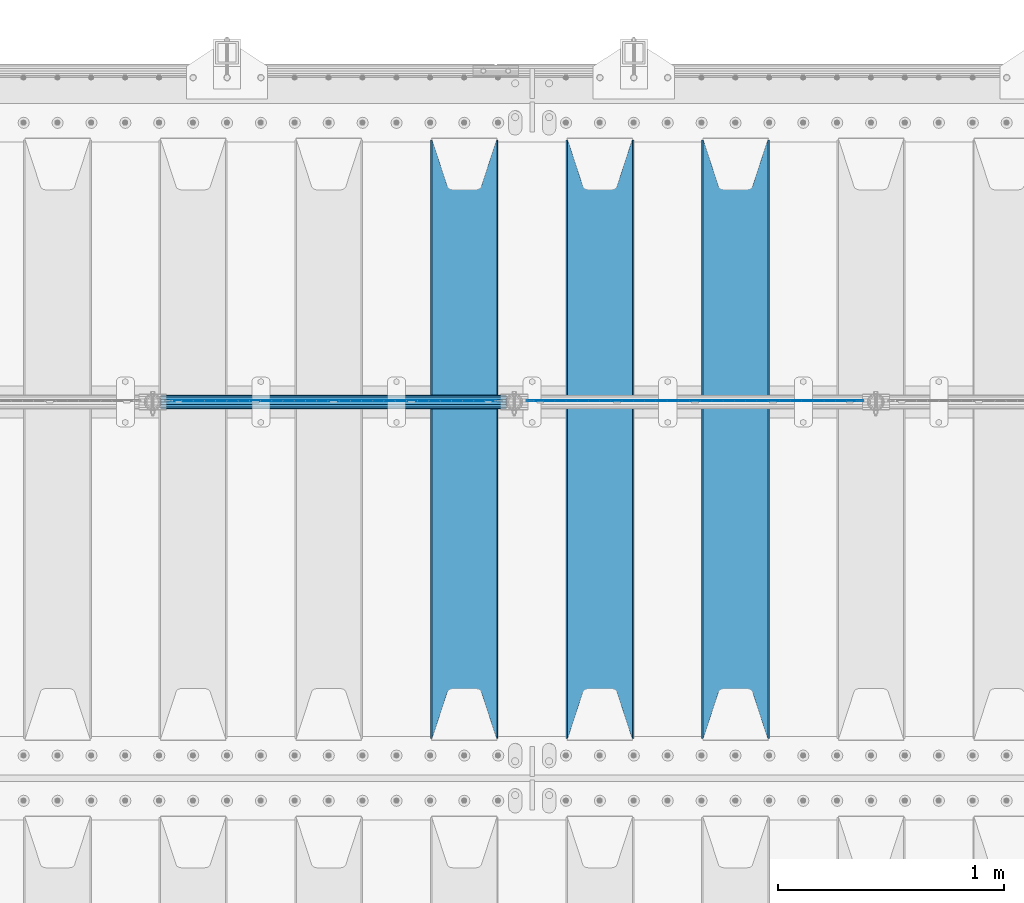
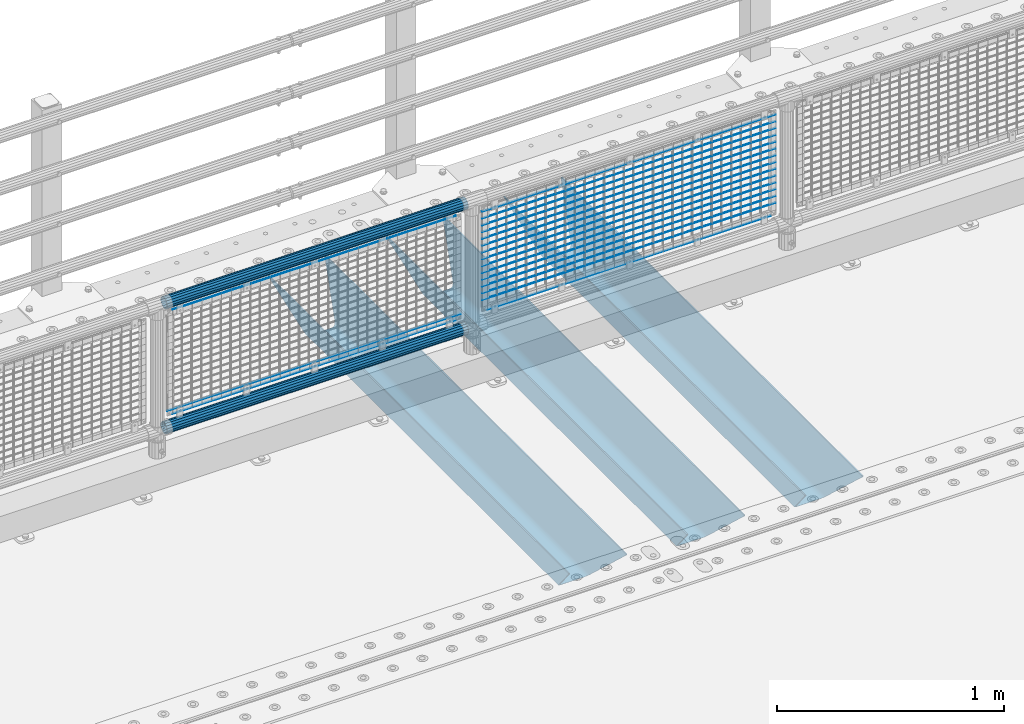
# One storey, part 96 of 208: 23 beams.
"""IFC2X3 building model written with IfcOpenShell, lengths in millimetres."""

from ifc_helpers import new_model, si_unit, frame, origin_with_axes, place, context, subcontext, project, spatial, faceted_brep, material, type_object, element, save


model = new_model("IFC2X3")

# Units and contexts
model_context = context("Model", 3, precision=1e-05, world=origin_with_axes())
body_context = subcontext(model_context, "Body", "Model", "MODEL_VIEW")
ifc_project = project(units=[si_unit("LENGTHUNIT", "METRE", prefix="MILLI"), si_unit("AREAUNIT", "SQUARE_METRE"), si_unit("VOLUMEUNIT", "CUBIC_METRE"), si_unit("MASSUNIT", "GRAM", prefix="KILO"), si_unit("TIMEUNIT", "SECOND"), si_unit("PLANEANGLEUNIT", "RADIAN"), si_unit("SOLIDANGLEUNIT", "STERADIAN"), si_unit("THERMODYNAMICTEMPERATUREUNIT", "DEGREE_CELSIUS"), si_unit("LUMINOUSINTENSITYUNIT", "LUMEN")], contexts=[model_context])

# Site, building, storey
site_placement = place(None, origin_with_axes())
site = spatial("IfcSite", under=ifc_project, at=site_placement, CompositionType="ELEMENT")
building_placement = place(site_placement, origin_with_axes())
building = spatial("IfcBuilding", under=site, at=building_placement, Name="Standard", CompositionType="ELEMENT")
storey_placement = place(building_placement, origin_with_axes())
storey = spatial("IfcBuildingStorey", under=building, at=storey_placement, Name="Undefined", CompositionType="ELEMENT", Elevation=0.0)

# Beams
ifc_material_1 = material(Name="STEEL/S355N")
beam_type_1 = type_object("IfcBeamType", PredefinedType="NOTDEFINED")
beam_1_placement = place(storey_placement, frame((-36050.0, 3175.0, -115.0), z_axis=(0.0, 0.0, 1.0), x_axis=(0.0, 1.0, 0.0)))
element("IfcBeam", 1, at=beam_1_placement, inside=storey, type_object=beam_type_1, material=ifc_material_1, context=body_context, shape_type="Brep", body=[
    faceted_brep([(0.0, 150.0, 115.0), (0.0, 143.689999999999, 115.0), (2650.00000000297, 143.689999999999, 115.0), (2650.00000000297, 150.0, 115.0), (2650.00000000297, 142.059565218402, 110.0000000031), (2650.00000000297, 148.369565218403, 110.0000000031), (2441.90079219208, -80.1103600731112, -98.0992078077845), (2437.7588105432, -77.5672621345584, -102.241189456673), (2434.06523489746, -74.4080125315522, -105.934765102404), (2430.91086095089, -70.710272125576, -109.089139048974), (2428.37322971128, -66.5649389910068, -111.626770288588), (2426.51472138055, -62.0739139532889, -113.485278619323), (2425.38102192091, -57.3475956567672, -114.618978078955), (2424.99999999987, -52.5021667386536, -115.0), (2424.99999999987, 52.5021667386536, -115.0), (2425.38102192091, 57.3475956567672, -114.618978078955), (2426.51472138055, 62.0739139532889, -113.485278619323), (2428.37322971128, 66.5649389910068, -111.626770288588), (2430.91086095089, 70.710272125576, -109.089139048974), (2434.06523489746, 74.4080125315522, -105.934765102404), (2437.7588105432, 77.5672621345584, -102.241189456673), (2441.90079219208, 80.1103600731112, -98.0992078077846), (2446.38936140511, 81.9747917625791, -93.6106385947584), (2448.24948500409, 76.2713538057251, -91.7505149957729), (2444.62967112262, 74.76777986261, -95.3703288772456), (2441.28936334126, 72.7168944282894, -98.710636658607), (2438.31067330438, 70.1691124903846, -101.689326695487), (2435.76682334747, 67.1870637758839, -104.233176652398), (2433.72034654133, 63.8440531834895, -106.279653458539), (2432.22154950041, 60.222258798236, -107.778450499454), (2431.30727574265, 56.4107117849089, -108.692724257221), (2430.99999999987, 52.5031078186876, -109.0), (2430.99999999987, -52.5031078186876, -109.0), (2431.30727574265, -56.4107117849089, -108.692724257221), (2432.22154950041, -60.222258798236, -107.778450499454), (2433.72034654133, -63.8440531834895, -106.279653458539), (2435.76682334747, -67.1870637758839, -104.233176652398), (2438.31067330438, -70.1691124903846, -101.689326695487), (2441.28936334126, -72.7168944282894, -98.7106366586071), (2444.62967112262, -74.76777986261, -95.3703288772457), (2448.24948500409, -76.2713538057251, -91.7505149957729), (2650.00000000297, -142.059565218402, 110.0000000031), (2650.00000000297, -148.369565218403, 110.0000000031), (2446.38936140511, -81.9747917625791, -93.6106385947584), (2650.00000000297, -143.689999999999, 115.0), (2650.00000000297, -150.0, 115.0), (0.0, -143.689999999999, 115.0), (0.0, -150.0, 115.0), (0.0, -148.369565218261, 110.000000002663), (203.610638597421, -81.9747917625791, -93.6106385947584), (208.099207810448, -80.1103600731112, -98.0992078077845), (212.241189459336, -77.5672621345584, -102.241189456673), (215.934765105067, -74.4080125315522, -105.934765102404), (219.089139051637, -70.710272125576, -109.089139048974), (221.626770291251, -66.5649389910068, -111.626770288588), (223.485278621986, -62.0739139532889, -113.485278619323), (224.618978081618, -57.3475956567672, -114.618978078955), (225.000000002663, -52.5021667386536, -115.0), (225.000000002663, 52.5021667386536, -115.0), (224.618978081618, 57.3475956567672, -114.618978078955), (223.485278621986, 62.0739139532889, -113.485278619323), (221.626770291251, 66.5649389910068, -111.626770288588), (219.089139051637, 70.710272125576, -109.089139048974), (215.934765105067, 74.4080125315522, -105.934765102404), (212.241189459336, 77.5672621345584, -102.241189456673), (208.099207810448, 80.1103600731112, -98.0992078077846), (203.610638597421, 81.9747917625791, -93.6106385947584), (0.0, 148.369565218261, 110.000000002663), (0.0, 142.05956521826, 110.000000002663), (201.750514998436, 76.2713538057251, -91.7505149957729), (205.370328879908, 74.76777986261, -95.3703288772456), (208.71063666127, 72.7168944282894, -98.710636658607), (211.68932669815, 70.1691124903846, -101.689326695487), (214.233176655061, 67.1870637758839, -104.233176652398), (216.279653461202, 63.8440531834895, -106.279653458539), (217.778450502116, 60.222258798236, -107.778450499454), (218.692724259884, 56.4107117849089, -108.692724257221), (219.000000002663, 52.5031078186876, -109.0), (219.000000002663, -52.5031078186876, -109.0), (218.692724259884, -56.4107117849089, -108.692724257221), (217.778450502116, -60.222258798236, -107.778450499454), (216.279653461202, -63.8440531834895, -106.279653458539), (214.233176655061, -67.1870637758839, -104.233176652398), (211.68932669815, -70.1691124903846, -101.689326695487), (208.71063666127, -72.7168944282894, -98.7106366586071), (205.370328879908, -74.76777986261, -95.3703288772457), (201.750514998436, -76.2713538057251, -91.7505149957729), (0.0, -142.05956521826, 110.000000002663)], [[[0, 1, 2, 3]], [[3, 2, 4, 5]], [[6, 7, 8, 9, 10, 11, 12, 13, 14, 15, 16, 17, 18, 19, 20, 21, 22, 5, 4, 23, 24, 25, 26, 27, 28, 29, 30, 31, 32, 33, 34, 35, 36, 37, 38, 39, 40, 41, 42, 43]], [[44, 45, 42, 41]], [[46, 47, 45, 44]], [[43, 42, 45, 47, 48, 49]], [[6, 43, 49, 50]], [[7, 6, 50, 51]], [[8, 7, 51, 52]], [[9, 8, 52, 53]], [[10, 9, 53, 54]], [[11, 10, 54, 55]], [[12, 11, 55, 56]], [[13, 12, 56, 57]], [[14, 13, 57, 58]], [[15, 14, 58, 59]], [[16, 15, 59, 60]], [[17, 16, 60, 61]], [[18, 17, 61, 62]], [[19, 18, 62, 63]], [[20, 19, 63, 64]], [[21, 20, 64, 65]], [[22, 21, 65, 66]], [[0, 3, 5, 22, 66, 67]], [[1, 0, 67, 68]], [[23, 4, 2, 1, 68, 69]], [[24, 23, 69, 70]], [[25, 24, 70, 71]], [[26, 25, 71, 72]], [[27, 26, 72, 73]], [[28, 27, 73, 74]], [[29, 28, 74, 75]], [[30, 29, 75, 76]], [[31, 30, 76, 77]], [[32, 31, 77, 78]], [[33, 32, 78, 79]], [[34, 33, 79, 80]], [[35, 34, 80, 81]], [[36, 35, 81, 82]], [[37, 36, 82, 83]], [[38, 37, 83, 84]], [[39, 38, 84, 85]], [[40, 39, 85, 86]], [[46, 44, 41, 40, 86, 87]], [[47, 46, 87, 48]], [[86, 85, 84, 83, 82, 81, 80, 79, 78, 77, 76, 75, 74, 73, 72, 71, 70, 69, 68, 67, 66, 65, 64, 63, 62, 61, 60, 59, 58, 57, 56, 55, 54, 53, 52, 51, 50, 49, 48, 87]]]),
])
beam_2_placement = place(storey_placement, frame((-36650.0, 3175.0, -115.0), z_axis=(0.0, 0.0, 1.0), x_axis=(0.0, 1.0, 0.0)))
element("IfcBeam", 2, at=beam_2_placement, inside=storey, type_object=beam_type_1, material=ifc_material_1, context=body_context, shape_type="Brep", body=[
    faceted_brep([(0.0, 150.0, 115.0), (0.0, 143.689999999999, 115.0), (2650.00000000297, 143.689999999999, 115.0), (2650.00000000297, 150.0, 115.0), (2650.00000000297, 142.059565218402, 110.0000000031), (2650.00000000297, 148.369565218403, 110.0000000031), (2441.90079219208, -80.1103600731112, -98.0992078077845), (2437.7588105432, -77.5672621345584, -102.241189456673), (2434.06523489746, -74.4080125315522, -105.934765102404), (2430.91086095089, -70.710272125576, -109.089139048974), (2428.37322971128, -66.5649389910068, -111.626770288588), (2426.51472138055, -62.0739139532889, -113.485278619323), (2425.38102192091, -57.3475956567672, -114.618978078955), (2424.99999999987, -52.5021667386536, -115.0), (2424.99999999987, 52.5021667386536, -115.0), (2425.38102192091, 57.3475956567672, -114.618978078955), (2426.51472138055, 62.0739139532889, -113.485278619323), (2428.37322971128, 66.5649389910068, -111.626770288588), (2430.91086095089, 70.710272125576, -109.089139048974), (2434.06523489746, 74.4080125315522, -105.934765102404), (2437.7588105432, 77.5672621345584, -102.241189456673), (2441.90079219208, 80.1103600731112, -98.0992078077846), (2446.38936140511, 81.9747917625791, -93.6106385947584), (2448.24948500409, 76.2713538057251, -91.7505149957729), (2444.62967112262, 74.76777986261, -95.3703288772456), (2441.28936334126, 72.7168944282894, -98.710636658607), (2438.31067330438, 70.1691124903846, -101.689326695487), (2435.76682334747, 67.1870637758839, -104.233176652398), (2433.72034654133, 63.8440531834895, -106.279653458539), (2432.22154950041, 60.222258798236, -107.778450499454), (2431.30727574265, 56.4107117849089, -108.692724257221), (2430.99999999987, 52.5031078186876, -109.0), (2430.99999999987, -52.5031078186876, -109.0), (2431.30727574265, -56.4107117849089, -108.692724257221), (2432.22154950041, -60.222258798236, -107.778450499454), (2433.72034654133, -63.8440531834895, -106.279653458539), (2435.76682334747, -67.1870637758839, -104.233176652398), (2438.31067330438, -70.1691124903846, -101.689326695487), (2441.28936334126, -72.7168944282894, -98.7106366586071), (2444.62967112262, -74.76777986261, -95.3703288772457), (2448.24948500409, -76.2713538057251, -91.7505149957729), (2650.00000000297, -142.059565218402, 110.0000000031), (2650.00000000297, -148.369565218403, 110.0000000031), (2446.38936140511, -81.9747917625791, -93.6106385947584), (2650.00000000297, -143.689999999999, 115.0), (2650.00000000297, -150.0, 115.0), (0.0, -143.689999999999, 115.0), (0.0, -150.0, 115.0), (0.0, -148.369565218261, 110.000000002663), (203.610638597421, -81.9747917625791, -93.6106385947584), (208.099207810448, -80.1103600731112, -98.0992078077845), (212.241189459336, -77.5672621345584, -102.241189456673), (215.934765105067, -74.4080125315522, -105.934765102404), (219.089139051637, -70.710272125576, -109.089139048974), (221.626770291251, -66.5649389910068, -111.626770288588), (223.485278621986, -62.0739139532889, -113.485278619323), (224.618978081618, -57.3475956567672, -114.618978078955), (225.000000002663, -52.5021667386536, -115.0), (225.000000002663, 52.5021667386536, -115.0), (224.618978081618, 57.3475956567672, -114.618978078955), (223.485278621986, 62.0739139532889, -113.485278619323), (221.626770291251, 66.5649389910068, -111.626770288588), (219.089139051637, 70.710272125576, -109.089139048974), (215.934765105067, 74.4080125315522, -105.934765102404), (212.241189459336, 77.5672621345584, -102.241189456673), (208.099207810448, 80.1103600731112, -98.0992078077846), (203.610638597421, 81.9747917625791, -93.6106385947584), (0.0, 148.369565218261, 110.000000002663), (0.0, 142.05956521826, 110.000000002663), (201.750514998436, 76.2713538057251, -91.7505149957729), (205.370328879908, 74.76777986261, -95.3703288772456), (208.71063666127, 72.7168944282894, -98.710636658607), (211.68932669815, 70.1691124903846, -101.689326695487), (214.233176655061, 67.1870637758839, -104.233176652398), (216.279653461202, 63.8440531834895, -106.279653458539), (217.778450502116, 60.222258798236, -107.778450499454), (218.692724259884, 56.4107117849089, -108.692724257221), (219.000000002663, 52.5031078186876, -109.0), (219.000000002663, -52.5031078186876, -109.0), (218.692724259884, -56.4107117849089, -108.692724257221), (217.778450502116, -60.222258798236, -107.778450499454), (216.279653461202, -63.8440531834895, -106.279653458539), (214.233176655061, -67.1870637758839, -104.233176652398), (211.68932669815, -70.1691124903846, -101.689326695487), (208.71063666127, -72.7168944282894, -98.7106366586071), (205.370328879908, -74.76777986261, -95.3703288772457), (201.750514998436, -76.2713538057251, -91.7505149957729), (0.0, -142.05956521826, 110.000000002663)], [[[0, 1, 2, 3]], [[3, 2, 4, 5]], [[6, 7, 8, 9, 10, 11, 12, 13, 14, 15, 16, 17, 18, 19, 20, 21, 22, 5, 4, 23, 24, 25, 26, 27, 28, 29, 30, 31, 32, 33, 34, 35, 36, 37, 38, 39, 40, 41, 42, 43]], [[44, 45, 42, 41]], [[46, 47, 45, 44]], [[43, 42, 45, 47, 48, 49]], [[6, 43, 49, 50]], [[7, 6, 50, 51]], [[8, 7, 51, 52]], [[9, 8, 52, 53]], [[10, 9, 53, 54]], [[11, 10, 54, 55]], [[12, 11, 55, 56]], [[13, 12, 56, 57]], [[14, 13, 57, 58]], [[15, 14, 58, 59]], [[16, 15, 59, 60]], [[17, 16, 60, 61]], [[18, 17, 61, 62]], [[19, 18, 62, 63]], [[20, 19, 63, 64]], [[21, 20, 64, 65]], [[22, 21, 65, 66]], [[0, 3, 5, 22, 66, 67]], [[1, 0, 67, 68]], [[23, 4, 2, 1, 68, 69]], [[24, 23, 69, 70]], [[25, 24, 70, 71]], [[26, 25, 71, 72]], [[27, 26, 72, 73]], [[28, 27, 73, 74]], [[29, 28, 74, 75]], [[30, 29, 75, 76]], [[31, 30, 76, 77]], [[32, 31, 77, 78]], [[33, 32, 78, 79]], [[34, 33, 79, 80]], [[35, 34, 80, 81]], [[36, 35, 81, 82]], [[37, 36, 82, 83]], [[38, 37, 83, 84]], [[39, 38, 84, 85]], [[40, 39, 85, 86]], [[46, 44, 41, 40, 86, 87]], [[47, 46, 87, 48]], [[86, 85, 84, 83, 82, 81, 80, 79, 78, 77, 76, 75, 74, 73, 72, 71, 70, 69, 68, 67, 66, 65, 64, 63, 62, 61, 60, 59, 58, 57, 56, 55, 54, 53, 52, 51, 50, 49, 48, 87]]]),
])
beam_3_placement = place(storey_placement, frame((-37250.0, 3175.0, -115.0), z_axis=(0.0, 0.0, 1.0), x_axis=(0.0, 1.0, 0.0)))
element("IfcBeam", 3, at=beam_3_placement, inside=storey, type_object=beam_type_1, material=ifc_material_1, context=body_context, shape_type="Brep", body=[
    faceted_brep([(0.0, 150.0, 115.0), (0.0, 143.689999999999, 115.0), (2650.00000000297, 143.689999999999, 115.0), (2650.00000000297, 150.0, 115.0), (2650.00000000297, 142.059565218402, 110.0000000031), (2650.00000000297, 148.369565218403, 110.0000000031), (2441.90079219208, -80.1103600731112, -98.0992078077845), (2437.7588105432, -77.5672621345584, -102.241189456673), (2434.06523489746, -74.4080125315522, -105.934765102404), (2430.91086095089, -70.710272125576, -109.089139048974), (2428.37322971128, -66.5649389910068, -111.626770288588), (2426.51472138055, -62.0739139532889, -113.485278619323), (2425.38102192091, -57.3475956567672, -114.618978078955), (2424.99999999987, -52.5021667386536, -115.0), (2424.99999999987, 52.5021667386536, -115.0), (2425.38102192091, 57.3475956567672, -114.618978078955), (2426.51472138055, 62.0739139532889, -113.485278619323), (2428.37322971128, 66.5649389910068, -111.626770288588), (2430.91086095089, 70.710272125576, -109.089139048974), (2434.06523489746, 74.4080125315522, -105.934765102404), (2437.7588105432, 77.5672621345584, -102.241189456673), (2441.90079219208, 80.1103600731112, -98.0992078077846), (2446.38936140511, 81.9747917625791, -93.6106385947584), (2448.24948500409, 76.2713538057251, -91.7505149957729), (2444.62967112262, 74.76777986261, -95.3703288772456), (2441.28936334126, 72.7168944282894, -98.710636658607), (2438.31067330438, 70.1691124903846, -101.689326695487), (2435.76682334747, 67.1870637758839, -104.233176652398), (2433.72034654133, 63.8440531834895, -106.279653458539), (2432.22154950041, 60.222258798236, -107.778450499454), (2431.30727574265, 56.4107117849089, -108.692724257221), (2430.99999999987, 52.5031078186876, -109.0), (2430.99999999987, -52.5031078186876, -109.0), (2431.30727574265, -56.4107117849089, -108.692724257221), (2432.22154950041, -60.222258798236, -107.778450499454), (2433.72034654133, -63.8440531834895, -106.279653458539), (2435.76682334747, -67.1870637758839, -104.233176652398), (2438.31067330438, -70.1691124903846, -101.689326695487), (2441.28936334126, -72.7168944282894, -98.7106366586071), (2444.62967112262, -74.76777986261, -95.3703288772457), (2448.24948500409, -76.2713538057251, -91.7505149957729), (2650.00000000297, -142.059565218402, 110.0000000031), (2650.00000000297, -148.369565218403, 110.0000000031), (2446.38936140511, -81.9747917625791, -93.6106385947584), (2650.00000000297, -143.689999999999, 115.0), (2650.00000000297, -150.0, 115.0), (0.0, -143.689999999999, 115.0), (0.0, -150.0, 115.0), (0.0, -148.369565218261, 110.000000002663), (203.610638597421, -81.9747917625791, -93.6106385947584), (208.099207810448, -80.1103600731112, -98.0992078077845), (212.241189459336, -77.5672621345584, -102.241189456673), (215.934765105067, -74.4080125315522, -105.934765102404), (219.089139051637, -70.710272125576, -109.089139048974), (221.626770291251, -66.5649389910068, -111.626770288588), (223.485278621986, -62.0739139532889, -113.485278619323), (224.618978081618, -57.3475956567672, -114.618978078955), (225.000000002663, -52.5021667386536, -115.0), (225.000000002663, 52.5021667386536, -115.0), (224.618978081618, 57.3475956567672, -114.618978078955), (223.485278621986, 62.0739139532889, -113.485278619323), (221.626770291251, 66.5649389910068, -111.626770288588), (219.089139051637, 70.710272125576, -109.089139048974), (215.934765105067, 74.4080125315522, -105.934765102404), (212.241189459336, 77.5672621345584, -102.241189456673), (208.099207810448, 80.1103600731112, -98.0992078077846), (203.610638597421, 81.9747917625791, -93.6106385947584), (0.0, 148.369565218261, 110.000000002663), (0.0, 142.05956521826, 110.000000002663), (201.750514998436, 76.2713538057251, -91.7505149957729), (205.370328879908, 74.76777986261, -95.3703288772456), (208.71063666127, 72.7168944282894, -98.710636658607), (211.68932669815, 70.1691124903846, -101.689326695487), (214.233176655061, 67.1870637758839, -104.233176652398), (216.279653461202, 63.8440531834895, -106.279653458539), (217.778450502116, 60.222258798236, -107.778450499454), (218.692724259884, 56.4107117849089, -108.692724257221), (219.000000002663, 52.5031078186876, -109.0), (219.000000002663, -52.5031078186876, -109.0), (218.692724259884, -56.4107117849089, -108.692724257221), (217.778450502116, -60.222258798236, -107.778450499454), (216.279653461202, -63.8440531834895, -106.279653458539), (214.233176655061, -67.1870637758839, -104.233176652398), (211.68932669815, -70.1691124903846, -101.689326695487), (208.71063666127, -72.7168944282894, -98.7106366586071), (205.370328879908, -74.76777986261, -95.3703288772457), (201.750514998436, -76.2713538057251, -91.7505149957729), (0.0, -142.05956521826, 110.000000002663)], [[[0, 1, 2, 3]], [[3, 2, 4, 5]], [[6, 7, 8, 9, 10, 11, 12, 13, 14, 15, 16, 17, 18, 19, 20, 21, 22, 5, 4, 23, 24, 25, 26, 27, 28, 29, 30, 31, 32, 33, 34, 35, 36, 37, 38, 39, 40, 41, 42, 43]], [[44, 45, 42, 41]], [[46, 47, 45, 44]], [[43, 42, 45, 47, 48, 49]], [[6, 43, 49, 50]], [[7, 6, 50, 51]], [[8, 7, 51, 52]], [[9, 8, 52, 53]], [[10, 9, 53, 54]], [[11, 10, 54, 55]], [[12, 11, 55, 56]], [[13, 12, 56, 57]], [[14, 13, 57, 58]], [[15, 14, 58, 59]], [[16, 15, 59, 60]], [[17, 16, 60, 61]], [[18, 17, 61, 62]], [[19, 18, 62, 63]], [[20, 19, 63, 64]], [[21, 20, 64, 65]], [[22, 21, 65, 66]], [[0, 3, 5, 22, 66, 67]], [[1, 0, 67, 68]], [[23, 4, 2, 1, 68, 69]], [[24, 23, 69, 70]], [[25, 24, 70, 71]], [[26, 25, 71, 72]], [[27, 26, 72, 73]], [[28, 27, 73, 74]], [[29, 28, 74, 75]], [[30, 29, 75, 76]], [[31, 30, 76, 77]], [[32, 31, 77, 78]], [[33, 32, 78, 79]], [[34, 33, 79, 80]], [[35, 34, 80, 81]], [[36, 35, 81, 82]], [[37, 36, 82, 83]], [[38, 37, 83, 84]], [[39, 38, 84, 85]], [[40, 39, 85, 86]], [[46, 44, 41, 40, 86, 87]], [[47, 46, 87, 48]], [[86, 85, 84, 83, 82, 81, 80, 79, 78, 77, 76, 75, 74, 73, 72, 71, 70, 69, 68, 67, 66, 65, 64, 63, 62, 61, 60, 59, 58, 57, 56, 55, 54, 53, 52, 51, 50, 49, 48, 87]]]),
])
ifc_material_2 = material(Name="Misc_Undefined")
beam_type_2 = type_object("IfcBeamType", Name="D3", PredefinedType="NOTDEFINED")
for number, where, z_axis, x_axis in (
    (4, (-36974.0, 4670.5, 851.597000000001), (0.0, 0.0, 1.0), (1.0, 0.0, 0.0)),
    (5, (-36974.0, 4670.5, 669.452000000001), (0.0, 0.0, 1.0), (1.0, 0.0, 0.0)),
    (6, (-36974.0, 4670.5, 523.736000000001), (0.0, 0.0, 1.0), (1.0, 0.0, 0.0)),
    (7, (-36974.0, 4670.5, 487.307000000001), (0.0, 0.0, 1.0), (1.0, 0.0, 0.0)),
    (8, (-36974.0, 4670.5, 705.881000000001), (0.0, 0.0, 1.0), (1.0, 0.0, 0.0)),
    (9, (-36974.0, 4670.5, 596.594000000001), (0.0, 0.0, 1.0), (1.0, 0.0, 0.0)),
    (10, (-36974.0, 4670.5, 450.878000000001), (0.0, 0.0, 1.0), (1.0, 0.0, 0.0)),
    (11, (-36974.0, 4670.5, 815.168000000001), (0.0, 0.0, 1.0), (1.0, 0.0, 0.0)),
    (12, (-36974.0, 4670.5, 888.026000000001), (0.0, 0.0, 1.0), (1.0, 0.0, 0.0)),
    (13, (-36974.0, 4670.5, 778.739000000001), (0.0, 0.0, 1.0), (1.0, 0.0, 0.0)),
    (14, (-36974.0, 4670.5, 742.310000000001), (0.0, 0.0, 1.0), (1.0, 0.0, 0.0)),
    (15, (-36974.0, 4670.5, 633.023000000001), (0.0, 0.0, 1.0), (1.0, 0.0, 0.0)),
    (16, (-36974.0, 4670.5, 560.165000000001), (0.0, 0.0, 1.0), (1.0, 0.0, 0.0)),
    (17, (-36974.0, 4670.5, 414.449000000001), (0.0, 0.0, 1.0), (1.0, 0.0, 0.0)),
):
    element("IfcBeam", number, at=place(storey_placement, frame(where, z_axis=z_axis, x_axis=x_axis)), inside=storey, type_object=beam_type_2, material=ifc_material_2, ObjectType="D3", context=body_context, shape_type="Brep", body=[
        faceted_brep([(0.0, -1.49999999999909, 3.63797880709171e-12), (-7.27595761418343e-12, -0.749999999999091, -1.29903810567669), (1490.0, -0.75, -1.29903810567669), (1490.0, -1.5, 0.0), (-3.63797880709171e-12, 0.750000000000909, -1.29903810567669), (1490.0, 0.75, -1.29903810567669), (0.0, 1.50000000000182, 3.63797880709171e-12), (1490.0, 1.5, 0.0), (-3.63797880709171e-12, 0.750000000000909, 1.29903810567669), (1490.0, 0.75, 1.29903810567669), (-7.27595761418343e-12, -0.749999999999091, 1.29903810567669), (1490.0, -0.75, 1.29903810567669)], [[[0, 1, 2, 3]], [[1, 4, 5, 2]], [[4, 6, 7, 5]], [[6, 8, 9, 7]], [[8, 10, 11, 9]], [[10, 0, 3, 11]], [[5, 7, 9, 11, 3, 2]], [[10, 8, 6, 4, 1, 0]]]),
    ])
for number, where, z_axis, x_axis in (
    (18, (-36949.0, 4670.5, 353.020000000001), (0.0, 0.0, 1.0), (1.0, 0.0, 0.0)),
    (19, (-38549.0, 4670.5, 353.02), (0.0, 0.0, 1.0), (1.0, 0.0, 0.0)),
):
    element("IfcBeam", number, at=place(storey_placement, frame(where, z_axis=z_axis, x_axis=x_axis)), inside=storey, type_object=beam_type_2, material=ifc_material_2, ObjectType="D3", context=body_context, shape_type="Brep", body=[
        faceted_brep([(0.0, -1.49999999999909, 3.63797880709171e-12), (-7.27595761418343e-12, -0.749999999999091, -1.29903810567669), (1440.0, -0.75, -1.29903810567669), (1440.0, -1.5, 0.0), (-3.63797880709171e-12, 0.750000000000909, -1.29903810567669), (1440.0, 0.75, -1.29903810567663), (0.0, 1.50000000000182, 3.63797880709171e-12), (1440.0, 1.5, 0.0), (-3.63797880709171e-12, 0.750000000000909, 1.29903810567669), (1440.0, 0.75, 1.29903810567669), (-7.27595761418343e-12, -0.749999999999091, 1.29903810567669), (1440.0, -0.75, 1.29903810567669)], [[[0, 1, 2, 3]], [[1, 4, 5, 2]], [[4, 6, 7, 5]], [[6, 8, 9, 7]], [[8, 10, 11, 9]], [[10, 0, 3, 11]], [[5, 7, 9, 11, 3, 2]], [[10, 8, 6, 4, 1, 0]]]),
    ])
beam_4_placement = place(storey_placement, frame((-38574.0, 4670.5, 378.02), z_axis=(0.0, 0.0, 1.0), x_axis=(1.0, 0.0, 0.0)))
element("IfcBeam", 20, at=beam_4_placement, inside=storey, type_object=beam_type_2, material=ifc_material_2, ObjectType="D3", context=body_context, shape_type="Brep", body=[
    faceted_brep([(0.0, -1.49999999999909, 3.63797880709171e-12), (-7.27595761418343e-12, -0.749999999999091, -1.29903810567669), (1490.0, -0.75, -1.29903810567669), (1490.0, -1.5, 0.0), (-3.63797880709171e-12, 0.750000000000909, -1.29903810567669), (1490.0, 0.75, -1.29903810567669), (0.0, 1.50000000000182, 3.63797880709171e-12), (1490.0, 1.5, 0.0), (-3.63797880709171e-12, 0.750000000000909, 1.29903810567669), (1490.0, 0.75, 1.29903810567669), (-7.27595761418343e-12, -0.749999999999091, 1.29903810567669), (1490.0, -0.75, 1.29903810567669)], [[[0, 1, 2, 3]], [[1, 4, 5, 2]], [[4, 6, 7, 5]], [[6, 8, 9, 7]], [[8, 10, 11, 9]], [[10, 0, 3, 11]], [[5, 7, 9, 11, 3, 2]], [[10, 8, 6, 4, 1, 0]]]),
])
beam_5_placement = place(storey_placement, frame((-38549.0, 4670.5, 913.02), z_axis=(0.0, 0.0, 1.0), x_axis=(1.0, 0.0, 0.0)))
element("IfcBeam", 21, at=beam_5_placement, inside=storey, type_object=beam_type_2, material=ifc_material_2, ObjectType="D3", context=body_context, shape_type="Brep", body=[
    faceted_brep([(0.0, -1.49999999999909, 3.63797880709171e-12), (-7.27595761418343e-12, -0.749999999999091, -1.29903810567669), (1440.0, -0.75, -1.29903810567669), (1440.0, -1.5, 0.0), (-3.63797880709171e-12, 0.750000000000909, -1.29903810567669), (1440.0, 0.75, -1.29903810567663), (0.0, 1.50000000000182, 3.63797880709171e-12), (1440.0, 1.5, 0.0), (-3.63797880709171e-12, 0.750000000000909, 1.29903810567669), (1440.0, 0.75, 1.29903810567669), (-7.27595761418343e-12, -0.749999999999091, 1.29903810567669), (1440.0, -0.75, 1.29903810567669)], [[[0, 1, 2, 3]], [[1, 4, 5, 2]], [[4, 6, 7, 5]], [[6, 8, 9, 7]], [[8, 10, 11, 9]], [[10, 0, 3, 11]], [[5, 7, 9, 11, 3, 2]], [[10, 8, 6, 4, 1, 0]]]),
])
ifc_material_3 = material()
beam_type_3 = type_object("IfcBeamType", PredefinedType="NOTDEFINED")
beam_6_placement = place(storey_placement, frame((-38594.15, 4664.5, 298.170000000002), z_axis=(0.0, 0.0, 1.0), x_axis=(1.0, 0.0, 0.0)))
element("IfcBeam", 22, at=beam_6_placement, inside=storey, type_object=beam_type_3, material=ifc_material_3, context=body_context, shape_type="Brep", body=[
    faceted_brep([(0.0, -25.3500000000004, 0.0), (0.0, -23.4203461491616, 9.70102501045403), (1530.0, -23.4203461491616, 9.70102501045506), (1530.0, -25.3500000000004, 0.0), (0.0, -17.9251569030794, 17.9251569030785), (1530.0, -17.9251569030794, 17.925156903079), (0.0, -9.70102501045494, 23.4203461491597), (1530.0, -9.70102501045494, 23.4203461491611), (0.0, 0.0, 25.3499999999985), (1530.0, 0.0, 25.35), (0.0, 9.70102501045494, 23.4203461491597), (1530.0, 9.70102501045494, 23.4203461491611), (0.0, 17.9251569030794, 17.9251569030785), (1530.0, 17.9251569030794, 17.925156903079), (0.0, 23.4203461491616, 9.70102501045403), (1530.0, 23.4203461491616, 9.701025010455), (0.0, 25.3500000000004, 0.0), (1530.0, 25.3500000000004, 0.0), (0.0, 23.4203461491616, -9.70102501045403), (1530.0, 23.4203461491616, -9.70102501045506), (0.0, 17.9251569030794, -17.9251569030785), (1530.0, 17.9251569030794, -17.925156903079), (0.0, 9.70102501045494, -23.4203461491597), (1530.0, 9.70102501045494, -23.4203461491611), (0.0, 0.0, -25.3499999999985), (1530.0, 0.0, -25.35), (0.0, -9.70102501045494, -23.4203461491597), (1530.0, -9.70102501045494, -23.4203461491611), (0.0, -17.9251569030794, -17.9251569030785), (1530.0, -17.9251569030794, -17.925156903079), (0.0, -23.4203461491616, -9.70102501045403), (1530.0, -23.4203461491616, -9.701025010455), (0.0, -30.1499999999996, 0.0), (0.0, -27.8549679052148, -11.5379054858058), (1530.0, -27.8549679052148, -11.5379054858075), (1530.0, -30.1499999999996, 0.0), (0.0, -21.3192694527743, -21.3192694527752), (1530.0, -21.3192694527743, -21.3192694527744), (0.0, -11.5379054858076, -27.8549679052157), (1530.0, -11.5379054858076, -27.8549679052153), (0.0, 0.0, -30.1500000000015), (1530.0, 0.0, -30.15), (0.0, 11.5379054858076, -27.8549679052157), (1530.0, 11.5379054858076, -27.8549679052153), (0.0, 21.3192694527743, -21.3192694527752), (1530.0, 21.3192694527743, -21.3192694527744), (0.0, 27.8549679052157, -11.5379054858058), (1530.0, 27.8549679052157, -11.5379054858075), (0.0, 30.1499999999996, 0.0), (1530.0, 30.1499999999996, 0.0), (0.0, 27.8549679052157, 11.5379054858058), (1530.0, 27.8549679052157, 11.5379054858075), (0.0, 21.3192694527743, 21.3192694527752), (1530.0, 21.3192694527743, 21.3192694527744), (0.0, 11.5379054858076, 27.8549679052157), (1530.0, 11.5379054858076, 27.8549679052153), (0.0, 0.0, 30.1500000000015), (1530.0, 0.0, 30.15), (0.0, -11.5379054858076, 27.8549679052157), (1530.0, -11.5379054858076, 27.8549679052153), (0.0, -21.3192694527743, 21.3192694527752), (1530.0, -21.3192694527743, 21.3192694527744), (0.0, -27.8549679052157, 11.5379054858058), (1530.0, -27.8549679052157, 11.5379054858075)], [[[0, 1, 2, 3]], [[1, 4, 5, 2]], [[4, 6, 7, 5]], [[6, 8, 9, 7]], [[8, 10, 11, 9]], [[10, 12, 13, 11]], [[12, 14, 15, 13]], [[14, 16, 17, 15]], [[16, 18, 19, 17]], [[18, 20, 21, 19]], [[20, 22, 23, 21]], [[22, 24, 25, 23]], [[24, 26, 27, 25]], [[26, 28, 29, 27]], [[28, 30, 31, 29]], [[30, 0, 3, 31]], [[32, 33, 34, 35]], [[33, 36, 37, 34]], [[36, 38, 39, 37]], [[38, 40, 41, 39]], [[40, 42, 43, 41]], [[42, 44, 45, 43]], [[44, 46, 47, 45]], [[46, 48, 49, 47]], [[48, 50, 51, 49]], [[50, 52, 53, 51]], [[52, 54, 55, 53]], [[54, 56, 57, 55]], [[56, 58, 59, 57]], [[58, 60, 61, 59]], [[60, 62, 63, 61]], [[62, 32, 35, 63]], [[37, 39, 41, 43, 45, 47, 49, 51, 53, 55, 57, 59, 61, 63, 35, 34], [5, 7, 9, 11, 13, 15, 17, 19, 21, 23, 25, 27, 29, 31, 3, 2]], [[62, 60, 58, 56, 54, 52, 50, 48, 46, 44, 42, 40, 38, 36, 33, 32], [30, 28, 26, 24, 22, 20, 18, 16, 14, 12, 10, 8, 6, 4, 1, 0]]]),
])
beam_7_placement = place(storey_placement, frame((-38594.15, 4664.5, 969.85), z_axis=(0.0, 0.0, 1.0), x_axis=(1.0, 0.0, 0.0)))
element("IfcBeam", 23, at=beam_7_placement, inside=storey, type_object=beam_type_3, material=ifc_material_3, context=body_context, shape_type="Brep", body=[
    faceted_brep([(0.0, -25.3500000000004, 0.0), (0.0, -23.4203461491616, 9.70102501045403), (1530.0, -23.4203461491616, 9.70102501045506), (1530.0, -25.3500000000004, 0.0), (0.0, -17.9251569030794, 17.9251569030785), (1530.0, -17.9251569030794, 17.925156903079), (0.0, -9.70102501045494, 23.4203461491597), (1530.0, -9.70102501045494, 23.4203461491611), (0.0, 0.0, 25.3499999999985), (1530.0, 0.0, 25.35), (0.0, 9.70102501045494, 23.4203461491597), (1530.0, 9.70102501045494, 23.4203461491611), (0.0, 17.9251569030794, 17.9251569030785), (1530.0, 17.9251569030794, 17.925156903079), (0.0, 23.4203461491616, 9.70102501045403), (1530.0, 23.4203461491616, 9.701025010455), (0.0, 25.3500000000004, 0.0), (1530.0, 25.3500000000004, 0.0), (0.0, 23.4203461491616, -9.70102501045403), (1530.0, 23.4203461491616, -9.70102501045506), (0.0, 17.9251569030794, -17.9251569030785), (1530.0, 17.9251569030794, -17.925156903079), (0.0, 9.70102501045494, -23.4203461491597), (1530.0, 9.70102501045494, -23.4203461491611), (0.0, 0.0, -25.3499999999985), (1530.0, 0.0, -25.35), (0.0, -9.70102501045494, -23.4203461491597), (1530.0, -9.70102501045494, -23.4203461491611), (0.0, -17.9251569030794, -17.9251569030785), (1530.0, -17.9251569030794, -17.925156903079), (0.0, -23.4203461491616, -9.70102501045403), (1530.0, -23.4203461491616, -9.701025010455), (0.0, -30.1499999999996, 0.0), (0.0, -27.8549679052148, -11.5379054858058), (1530.0, -27.8549679052148, -11.5379054858075), (1530.0, -30.1499999999996, 0.0), (0.0, -21.3192694527743, -21.3192694527752), (1530.0, -21.3192694527743, -21.3192694527744), (0.0, -11.5379054858076, -27.8549679052157), (1530.0, -11.5379054858076, -27.8549679052153), (0.0, 0.0, -30.1500000000015), (1530.0, 0.0, -30.15), (0.0, 11.5379054858076, -27.8549679052157), (1530.0, 11.5379054858076, -27.8549679052153), (0.0, 21.3192694527743, -21.3192694527752), (1530.0, 21.3192694527743, -21.3192694527744), (0.0, 27.8549679052157, -11.5379054858058), (1530.0, 27.8549679052157, -11.5379054858075), (0.0, 30.1499999999996, 0.0), (1530.0, 30.1499999999996, 0.0), (0.0, 27.8549679052157, 11.5379054858058), (1530.0, 27.8549679052157, 11.5379054858075), (0.0, 21.3192694527743, 21.3192694527752), (1530.0, 21.3192694527743, 21.3192694527744), (0.0, 11.5379054858076, 27.8549679052157), (1530.0, 11.5379054858076, 27.8549679052153), (0.0, 0.0, 30.1500000000015), (1530.0, 0.0, 30.15), (0.0, -11.5379054858076, 27.8549679052157), (1530.0, -11.5379054858076, 27.8549679052153), (0.0, -21.3192694527743, 21.3192694527752), (1530.0, -21.3192694527743, 21.3192694527744), (0.0, -27.8549679052157, 11.5379054858058), (1530.0, -27.8549679052157, 11.5379054858075)], [[[0, 1, 2, 3]], [[1, 4, 5, 2]], [[4, 6, 7, 5]], [[6, 8, 9, 7]], [[8, 10, 11, 9]], [[10, 12, 13, 11]], [[12, 14, 15, 13]], [[14, 16, 17, 15]], [[16, 18, 19, 17]], [[18, 20, 21, 19]], [[20, 22, 23, 21]], [[22, 24, 25, 23]], [[24, 26, 27, 25]], [[26, 28, 29, 27]], [[28, 30, 31, 29]], [[30, 0, 3, 31]], [[32, 33, 34, 35]], [[33, 36, 37, 34]], [[36, 38, 39, 37]], [[38, 40, 41, 39]], [[40, 42, 43, 41]], [[42, 44, 45, 43]], [[44, 46, 47, 45]], [[46, 48, 49, 47]], [[48, 50, 51, 49]], [[50, 52, 53, 51]], [[52, 54, 55, 53]], [[54, 56, 57, 55]], [[56, 58, 59, 57]], [[58, 60, 61, 59]], [[60, 62, 63, 61]], [[62, 32, 35, 63]], [[37, 39, 41, 43, 45, 47, 49, 51, 53, 55, 57, 59, 61, 63, 35, 34], [5, 7, 9, 11, 13, 15, 17, 19, 21, 23, 25, 27, 29, 31, 3, 2]], [[62, 60, 58, 56, 54, 52, 50, 48, 46, 44, 42, 40, 38, 36, 33, 32], [30, 28, 26, 24, 22, 20, 18, 16, 14, 12, 10, 8, 6, 4, 1, 0]]]),
])

save(model, "model.ifc")
